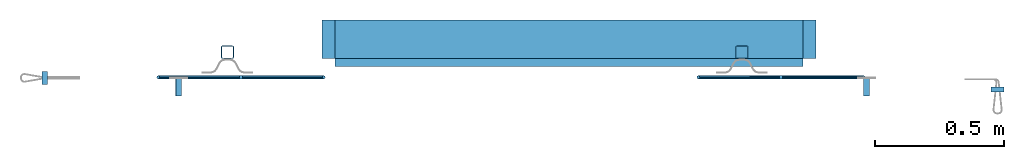
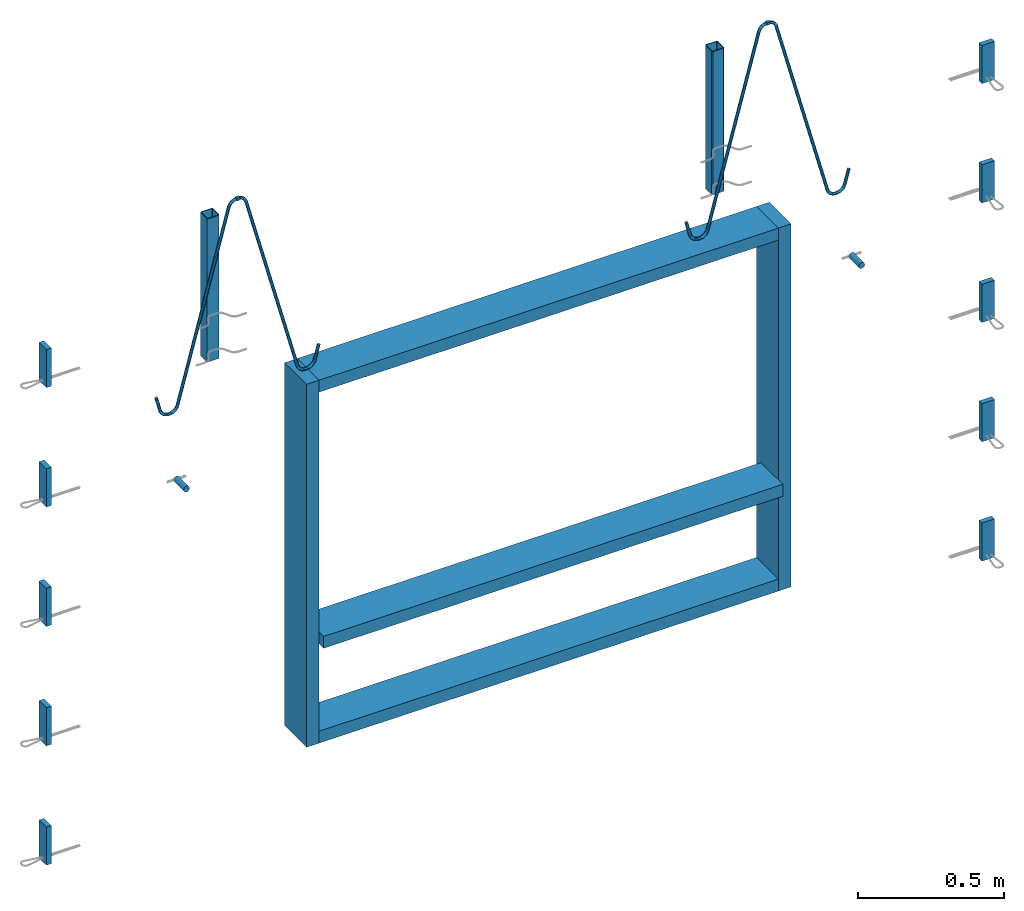
# One storey, part 1 of 5: 11 beams, 10 plates, 2 reinforcing bars, 21 elements without a shape of their own.
"""IFC2X3 building model written with IfcOpenShell, lengths in millimetres."""

from ifc_helpers import new_model, entity, si_unit, frame, origin_with_axes, origin_2d_with_axis, place, context, subcontext, project, spatial, polyline, rectangle, hollow_rectangle, circle, outline, extrude, source, transform, mapped, material, type_object, element, aggregate, save


model = new_model("IFC2X3")

# Units and contexts
model_context = context("Model", 3, precision=1e-05, world=origin_with_axes())
body_context = subcontext(model_context, "Body", "Model", "MODEL_VIEW")
ifc_project = project(units=[si_unit("LENGTHUNIT", "METRE", prefix="MILLI"), si_unit("AREAUNIT", "SQUARE_METRE"), si_unit("VOLUMEUNIT", "CUBIC_METRE"), si_unit("MASSUNIT", "GRAM", prefix="KILO"), si_unit("TIMEUNIT", "SECOND"), si_unit("PLANEANGLEUNIT", "RADIAN"), si_unit("SOLIDANGLEUNIT", "STERADIAN"), si_unit("THERMODYNAMICTEMPERATUREUNIT", "DEGREE_CELSIUS"), si_unit("LUMINOUSINTENSITYUNIT", "LUMEN")], contexts=[model_context])

# Site, building, storey
site_placement = place(None, origin_with_axes())
site = spatial("IfcSite", under=ifc_project, at=site_placement, CompositionType="ELEMENT")
building_placement = place(site_placement, origin_with_axes())
building = spatial("IfcBuilding", under=site, at=building_placement, Name="Undefined", CompositionType="ELEMENT")
storey_placement = place(building_placement, origin_with_axes())
storey = spatial("IfcBuildingStorey", under=building, at=storey_placement, Name="Undefined", CompositionType="ELEMENT", Elevation=0.0)

# Assembly, beam
assembly_1_placement = place(storey_placement, origin_with_axes())
assembly_1 = element("IfcElementAssembly", 1, at=assembly_1_placement, inside=storey, AssemblyPlace="NOTDEFINED", PredefinedType="NOTDEFINED")
ifc_material_1 = material(Name="TIMBER/C24")
beam_type_1 = type_object("IfcBeamType", Name="50X150", PredefinedType="NOTDEFINED")
beam_1_placement = place(assembly_1_placement, frame((37138.5237091595, 6694.96507881058, 1074.99992151564), z_axis=(0.0, 0.0, 1.0), x_axis=(0.999999999544916, -3.0168999986316e-05, 0.0)))
beam_1 = element("IfcBeam", 2, at=beam_1_placement, type_object=beam_type_1, material=ifc_material_1, ObjectType="50X150", context=body_context, shape_type="SweptSolid", body=[
    extrude(rectangle(XDim=150.0, YDim=50.0, at=origin_2d_with_axis()), frame((1819.99999996996, 6.16639985590952e-18, 0.0), z_axis=(-1.0, -1.81898940356404e-12, 1.55293650763585e-12), x_axis=(1.81898940356404e-12, -1.0, -1.87523373262748e-24)), (0.0, 0.0, 1.0), 1820.0),
])
aggregate(assembly_1, [beam_1])

assembly_2_placement = place(storey_placement, origin_with_axes())
assembly_2 = element("IfcElementAssembly", 3, at=assembly_2_placement, inside=storey, AssemblyPlace="NOTDEFINED", PredefinedType="NOTDEFINED")
beam_type_2 = type_object("IfcBeamType", Name="150X50", PredefinedType="NOTDEFINED")
beam_2_placement = place(assembly_2_placement, frame((37138.5246142217, 6724.96507879908, 659.999921515637), z_axis=(-3.01689999832888e-05, -0.999999999544916, 0.0), x_axis=(0.999999999544916, -3.0168999986316e-05, 0.0)))
beam_2 = element("IfcBeam", 4, at=beam_2_placement, type_object=beam_type_2, material=ifc_material_1, ObjectType="150X50", context=body_context, shape_type="SweptSolid", body=[
    extrude(rectangle(XDim=50.0, YDim=150.0, at=origin_2d_with_axis()), frame((1819.99999996996, 6.16639985590952e-18, 0.0), z_axis=(-1.0, -1.81898940356404e-12, 1.55293650763585e-12), x_axis=(1.81898940356404e-12, -1.0, -1.87523373262748e-24)), (0.0, 0.0, 1.0), 1820.0),
])
aggregate(assembly_2, [beam_2])

assembly_3_placement = place(storey_placement, origin_with_axes())
assembly_3 = element("IfcElementAssembly", 5, at=assembly_3_placement, inside=storey, AssemblyPlace="NOTDEFINED", PredefinedType="NOTDEFINED")
beam_3_placement = place(assembly_3_placement, frame((37113.5246142332, 6724.96583302412, 2154.99992151564), z_axis=(-3.01689999832888e-05, -0.999999999544916, 0.0), x_axis=(0.0, 0.0, -1.0)))
beam_3 = element("IfcBeam", 6, at=beam_3_placement, type_object=beam_type_2, material=ifc_material_1, ObjectType="150X50", context=body_context, shape_type="SweptSolid", body=[
    extrude(rectangle(XDim=50.0, YDim=150.0, at=origin_2d_with_axis()), frame((1520.0, -7.27595761418343e-12, -9.09494701772928e-13), z_axis=(-1.0, -1.81898940356404e-12, 1.55293650763585e-12), x_axis=(1.81898940356404e-12, -1.0, -1.87523373262748e-24)), (0.0, 0.0, 1.0), 1520.0),
])
aggregate(assembly_3, [beam_3])

assembly_4_placement = place(storey_placement, origin_with_axes())
assembly_4 = element("IfcElementAssembly", 7, at=assembly_4_placement, inside=storey, AssemblyPlace="NOTDEFINED", PredefinedType="NOTDEFINED")
beam_4_placement = place(assembly_4_placement, frame((38958.5246125429, 6724.91017122622, 2129.99992151563), z_axis=(-3.01689999832888e-05, -0.999999999544916, 0.0), x_axis=(-0.999999999544916, 3.01689999841786e-05, 0.0)))
beam_4 = element("IfcBeam", 8, at=beam_4_placement, type_object=beam_type_2, material=ifc_material_1, ObjectType="150X50", context=body_context, shape_type="SweptSolid", body=[
    extrude(rectangle(XDim=50.0, YDim=150.0, at=origin_2d_with_axis()), frame((1819.99999996996, 6.16639985590952e-18, 0.0), z_axis=(-1.0, -1.81898940356404e-12, 1.55293650763585e-12), x_axis=(1.81898940356404e-12, -1.0, -1.87523373262748e-24)), (0.0, 0.0, 1.0), 1820.0),
])
aggregate(assembly_4, [beam_4])

assembly_5_placement = place(storey_placement, origin_with_axes())
assembly_5 = element("IfcElementAssembly", 9, at=assembly_5_placement, inside=storey, AssemblyPlace="NOTDEFINED", PredefinedType="NOTDEFINED")
beam_5_placement = place(assembly_5_placement, frame((38983.5246125315, 6724.90941700118, 634.999921515635), z_axis=(-3.01689999832888e-05, -0.999999999544916, 0.0), x_axis=(0.0, 0.0, 1.0)))
beam_5 = element("IfcBeam", 10, at=beam_5_placement, type_object=beam_type_2, material=ifc_material_1, ObjectType="150X50", context=body_context, shape_type="SweptSolid", body=[
    extrude(rectangle(XDim=50.0, YDim=150.0, at=origin_2d_with_axis()), frame((1520.0, -7.27595761418343e-12, -9.09494701772928e-13), z_axis=(-1.0, -1.81898940356404e-12, 1.55293650763585e-12), x_axis=(1.81898940356404e-12, -1.0, -1.87523373262748e-24)), (0.0, 0.0, 1.0), 1520.0),
])
aggregate(assembly_5, [beam_5])

assembly_6_placement = place(storey_placement, origin_with_axes())
assembly_6 = element("IfcElementAssembly", 11, at=assembly_6_placement, inside=storey, Name="Steel Assembly", AssemblyPlace="NOTDEFINED", PredefinedType="RIGID_FRAME")
ifc_material_2 = material(Name="STEEL/S235JR")
beam_type_3 = type_object("IfcBeamType", Name="12X12", PredefinedType="NOTDEFINED")
beam_6_placement = place(assembly_6_placement, frame((38878.7217910362, 6577.27924703083, 3088.99992148861), z_axis=(0.0, 0.0, 1.0), x_axis=(-0.999999999544916, 3.01689999841786e-05, 0.0)))
beam_6 = element("IfcBeam", 12, at=beam_6_placement, type_object=beam_type_3, material=ifc_material_2, Name="SA_12", ObjectType="12X12", context=body_context, shape_type="SweptSolid", body=[
    extrude(rectangle(XDim=12.0, YDim=12.0, at=origin_2d_with_axis()), frame((11.9999999996475, 0.0, 4.54747350886464e-13), z_axis=(-1.0, -1.81898940356404e-12, 1.55293650763585e-12), x_axis=(1.81898940356404e-12, -1.0, -1.87523373262748e-24)), (0.0, 0.0, 1.0), 12.0),
])

assembly_7_placement = place(storey_placement, origin_with_axes())
assembly_7 = element("IfcElementAssembly", 13, at=assembly_7_placement, inside=storey, Name="Steel Assembly", AssemblyPlace="NOTDEFINED", PredefinedType="RIGID_FRAME")
beam_7_placement = place(assembly_7_placement, frame((36766.7217920601, 6577.34296393511, 3088.9999214886), z_axis=(0.0, 0.0, 1.0), x_axis=(0.999999999544916, -3.0168999986316e-05, 0.0)))
beam_7 = element("IfcBeam", 14, at=beam_7_placement, type_object=beam_type_3, material=ifc_material_2, Name="SA_12", ObjectType="12X12", context=body_context, shape_type="SweptSolid", body=[
    extrude(rectangle(XDim=12.0, YDim=12.0, at=origin_2d_with_axis()), frame((11.9999999996475, 0.0, 4.54747350886464e-13), z_axis=(-1.0, -1.81898940356404e-12, 1.55293650763585e-12), x_axis=(1.81898940356404e-12, -1.0, -1.87523373262748e-24)), (0.0, 0.0, 1.0), 12.0),
])

assembly_8_placement = place(storey_placement, origin_with_axes())
assembly_8 = element("IfcElementAssembly", 15, at=assembly_8_placement, inside=storey, Name="Steel Assembly", AssemblyPlace="NOTDEFINED", PredefinedType="RIGID_FRAME")
ifc_material_3 = material(Name="STEEL/S235J0")
beam_type_4 = type_object("IfcBeamType", Name="P50X50X3", PredefinedType="NOTDEFINED")
beam_8_placement = place(assembly_8_placement, frame((38720.0052770565, 6674.9173671186, 2984.99992151562), z_axis=(0.999999999544916, -3.0168999986316e-05, 0.0), x_axis=(0.0, 0.0, -1.0)))
beam_8 = element("IfcBeam", 16, at=beam_8_placement, type_object=beam_type_4, material=ifc_material_3, Name="200", ObjectType="P50X50X3", context=body_context, shape_type="SweptSolid", body=[
    extrude(hollow_rectangle(XDim=50.0, YDim=50.0, WallThickness=3.0, InnerFilletRadius=3.0, OuterFilletRadius=6.0, at=origin_2d_with_axis()), frame((600.0, 9.09494701772928e-13, 0.0), z_axis=(-1.0, -1.81898940356404e-12, 1.55293650763585e-12), x_axis=(1.81898940356404e-12, -1.0, -1.87523373262748e-24)), (0.0, 0.0, 1.0), 600.0),
])
aggregate(assembly_8, [beam_8])

assembly_9_placement = place(storey_placement, origin_with_axes())
assembly_9 = element("IfcElementAssembly", 17, at=assembly_9_placement, inside=storey, Name="Steel Assembly", AssemblyPlace="NOTDEFINED", PredefinedType="RIGID_FRAME")
beam_9_placement = place(assembly_9_placement, frame((36720.0052789693, 6674.9777050962, 2984.99992151562), z_axis=(0.999999999544916, -3.0168999986316e-05, 0.0), x_axis=(0.0, 0.0, -1.0)))
beam_9 = element("IfcBeam", 18, at=beam_9_placement, type_object=beam_type_4, material=ifc_material_3, Name="200", ObjectType="P50X50X3", context=body_context, shape_type="SweptSolid", body=[
    extrude(hollow_rectangle(XDim=50.0, YDim=50.0, WallThickness=3.0, InnerFilletRadius=3.0, OuterFilletRadius=6.0, at=origin_2d_with_axis()), frame((600.0, 9.09494701772928e-13, 0.0), z_axis=(-1.0, -1.81898940356404e-12, 1.55293650763585e-12), x_axis=(1.81898940356404e-12, -1.0, -1.87523373262748e-24)), (0.0, 0.0, 1.0), 600.0),
])
aggregate(assembly_9, [beam_9])

assembly_10_placement = place(storey_placement, origin_with_axes())
assembly_10 = element("IfcElementAssembly", 19, at=assembly_10_placement, inside=storey, Name="Steel Assembly", AssemblyPlace="NOTDEFINED", PredefinedType="RIGID_FRAME")
ifc_material_4 = material()
beam_type_5 = type_object("IfcBeamType", Name="D24", PredefinedType="NOTDEFINED")
beam_10_placement = place(assembly_10_placement, frame((39204.4034583971, 6504.90275308546, 1999.99992149192), z_axis=(0.0, 0.0, 1.0), x_axis=(3.01689999468154e-05, 0.999999999544916, 0.0)))
beam_10 = element("IfcBeam", 20, at=beam_10_placement, type_object=beam_type_5, material=ifc_material_4, ObjectType="D24", context=body_context, shape_type="SweptSolid", body=[
    extrude(circle(Radius=12.0, at=origin_2d_with_axis()), frame((70.0000000002146, 0.0, 2.27373675443232e-13), z_axis=(-1.0, -1.81898940356404e-12, 1.55293650763585e-12), x_axis=(1.81898940356404e-12, -1.0, -1.87523373262748e-24)), (0.0, 0.0, 1.0), 70.0),
])
aggregate(assembly_10, [beam_10])

assembly_11_placement = place(storey_placement, origin_with_axes())
assembly_11 = element("IfcElementAssembly", 21, at=assembly_11_placement, inside=storey, Name="Steel Assembly", AssemblyPlace="NOTDEFINED", PredefinedType="RIGID_FRAME")
beam_11_placement = place(assembly_11_placement, frame((36530.0001506199, 6504.98343725059, 1999.99992151153), z_axis=(0.0, 0.0, 1.0), x_axis=(3.01689999468154e-05, 0.999999999544916, 0.0)))
beam_11 = element("IfcBeam", 22, at=beam_11_placement, type_object=beam_type_5, material=ifc_material_4, ObjectType="D24", context=body_context, shape_type="SweptSolid", body=[
    extrude(circle(Radius=12.0, at=origin_2d_with_axis()), frame((70.0000000002146, 0.0, 2.27373675443232e-13), z_axis=(-1.0, -1.81898940356404e-12, 1.55293650763585e-12), x_axis=(1.81898940356404e-12, -1.0, -1.87523373262748e-24)), (0.0, 0.0, 1.0), 70.0),
])
aggregate(assembly_11, [beam_11])

# Assembly, plate
assembly_12_placement = place(storey_placement, origin_with_axes())
assembly_12 = element("IfcElementAssembly", 23, at=assembly_12_placement, inside=storey, Name="Steel Assembly", AssemblyPlace="NOTDEFINED", PredefinedType="RIGID_FRAME")
ifc_material_5 = material(Name="STEEL/Steel_Undefined")
plate_type = type_object("IfcPlateType", Name="PL160X20", PredefinedType="NOTDEFINED")
plate_1_placement = place(assembly_12_placement, frame((36000.0015084882, 6549.99942681672, 2662.49992151557), z_axis=(0.0, 0.0, -1.0), x_axis=(3.01689999468154e-05, 0.999999999544916, 0.0)))
plate_1 = element("IfcPlate", 24, at=plate_1_placement, type_object=plate_type, material=ifc_material_5, Name="PVL80", ObjectType="PL160X20", context=body_context, shape_type="SweptSolid", body=[
    extrude(outline(polyline([(0.0, 0.0), (50.000000000101, 1.96450855582952e-10), (50.0000000001401, 19.9999999997963), (-3.09228198602796e-11, 19.9999999995998), (0.0, 0.0)])), frame((0.0, 0.0, -80.0000000000005), z_axis=(0.0, 0.0, 1.0), x_axis=(1.0, 0.0, 0.0)), (0.0, 0.0, 1.0), 160.0),
])
aggregate(assembly_12, [plate_1])

assembly_13_placement = place(storey_placement, origin_with_axes())
assembly_13 = element("IfcElementAssembly", 25, at=assembly_13_placement, inside=storey, Name="Steel Assembly", AssemblyPlace="NOTDEFINED", PredefinedType="RIGID_FRAME")
plate_2_placement = place(assembly_13_placement, frame((39739.4018553944, 6519.89476329136, 2662.49992151563), z_axis=(0.0, 0.0, -1.0), x_axis=(-0.999999999544916, 3.01689999841786e-05, 0.0)))
plate_2 = element("IfcPlate", 26, at=plate_2_placement, type_object=plate_type, material=ifc_material_5, Name="PVL80", ObjectType="PL160X20", context=body_context, shape_type="SweptSolid", body=[
    extrude(outline(polyline([(0.0, 0.0), (50.000000000101, 1.96450855582952e-10), (50.0000000001401, 19.9999999997963), (-3.09228198602796e-11, 19.9999999995998), (0.0, 0.0)])), frame((0.0, 0.0, -80.0000000000005), z_axis=(0.0, 0.0, 1.0), x_axis=(1.0, 0.0, 0.0)), (0.0, 0.0, 1.0), 160.0),
])
aggregate(assembly_13, [plate_2])

assembly_14_placement = place(storey_placement, origin_with_axes())
assembly_14 = element("IfcElementAssembly", 27, at=assembly_14_placement, inside=storey, Name="Steel Assembly", AssemblyPlace="NOTDEFINED", PredefinedType="RIGID_FRAME")
plate_3_placement = place(assembly_14_placement, frame((39739.4018553907, 6519.89476329159, 2162.49992151543), z_axis=(0.0, 0.0, -1.0), x_axis=(-0.999999999544916, 3.01689999841786e-05, 0.0)))
plate_3 = element("IfcPlate", 28, at=plate_3_placement, type_object=plate_type, material=ifc_material_5, Name="PVL80", ObjectType="PL160X20", context=body_context, shape_type="SweptSolid", body=[
    extrude(outline(polyline([(0.0, 0.0), (50.000000000101, 1.96450855582952e-10), (50.0000000001401, 19.9999999997963), (-3.09228198602796e-11, 19.9999999995998), (0.0, 0.0)])), frame((0.0, 0.0, -80.0000000000005), z_axis=(0.0, 0.0, 1.0), x_axis=(1.0, 0.0, 0.0)), (0.0, 0.0, 1.0), 160.0),
])
aggregate(assembly_14, [plate_3])

assembly_15_placement = place(storey_placement, origin_with_axes())
assembly_15 = element("IfcElementAssembly", 29, at=assembly_15_placement, inside=storey, Name="Steel Assembly", AssemblyPlace="NOTDEFINED", PredefinedType="RIGID_FRAME")
plate_4_placement = place(assembly_15_placement, frame((39739.4018553916, 6519.89476329159, 1662.49992151543), z_axis=(0.0, 0.0, -1.0), x_axis=(-0.999999999544916, 3.01689999841786e-05, 0.0)))
plate_4 = element("IfcPlate", 30, at=plate_4_placement, type_object=plate_type, material=ifc_material_5, Name="PVL80", ObjectType="PL160X20", context=body_context, shape_type="SweptSolid", body=[
    extrude(outline(polyline([(0.0, 0.0), (50.000000000101, 1.96450855582952e-10), (50.0000000001401, 19.9999999997963), (-3.09228198602796e-11, 19.9999999995998), (0.0, 0.0)])), frame((0.0, 0.0, -80.0000000000005), z_axis=(0.0, 0.0, 1.0), x_axis=(1.0, 0.0, 0.0)), (0.0, 0.0, 1.0), 160.0),
])
aggregate(assembly_15, [plate_4])

assembly_16_placement = place(storey_placement, origin_with_axes())
assembly_16 = element("IfcElementAssembly", 31, at=assembly_16_placement, inside=storey, Name="Steel Assembly", AssemblyPlace="NOTDEFINED", PredefinedType="RIGID_FRAME")
plate_5_placement = place(assembly_16_placement, frame((39739.4018553925, 6519.89476329159, 1162.49992151543), z_axis=(0.0, 0.0, -1.0), x_axis=(-0.999999999544916, 3.01689999841786e-05, 0.0)))
plate_5 = element("IfcPlate", 32, at=plate_5_placement, type_object=plate_type, material=ifc_material_5, Name="PVL80", ObjectType="PL160X20", context=body_context, shape_type="SweptSolid", body=[
    extrude(outline(polyline([(0.0, 0.0), (50.000000000101, 1.96450855582952e-10), (50.0000000001401, 19.9999999997963), (-3.09228198602796e-11, 19.9999999995998), (0.0, 0.0)])), frame((0.0, 0.0, -80.0000000000005), z_axis=(0.0, 0.0, 1.0), x_axis=(1.0, 0.0, 0.0)), (0.0, 0.0, 1.0), 160.0),
])
aggregate(assembly_16, [plate_5])

assembly_17_placement = place(storey_placement, origin_with_axes())
assembly_17 = element("IfcElementAssembly", 33, at=assembly_17_placement, inside=storey, Name="Steel Assembly", AssemblyPlace="NOTDEFINED", PredefinedType="RIGID_FRAME")
plate_6_placement = place(assembly_17_placement, frame((39739.4018553934, 6519.89476329159, 662.499921515427), z_axis=(0.0, 0.0, -1.0), x_axis=(-0.999999999544916, 3.01689999841786e-05, 0.0)))
plate_6 = element("IfcPlate", 34, at=plate_6_placement, type_object=plate_type, material=ifc_material_5, Name="PVL80", ObjectType="PL160X20", context=body_context, shape_type="SweptSolid", body=[
    extrude(outline(polyline([(0.0, 0.0), (50.000000000101, 1.96450855582952e-10), (50.0000000001401, 19.9999999997963), (-3.09228198602796e-11, 19.9999999995998), (0.0, 0.0)])), frame((0.0, 0.0, -80.0000000000005), z_axis=(0.0, 0.0, 1.0), x_axis=(1.0, 0.0, 0.0)), (0.0, 0.0, 1.0), 160.0),
])
aggregate(assembly_17, [plate_6])

assembly_18_placement = place(storey_placement, origin_with_axes())
assembly_18 = element("IfcElementAssembly", 35, at=assembly_18_placement, inside=storey, Name="Steel Assembly", AssemblyPlace="NOTDEFINED", PredefinedType="RIGID_FRAME")
plate_7_placement = place(assembly_18_placement, frame((36000.0015084842, 6549.99942681677, 2162.49992151551), z_axis=(0.0, 0.0, -1.0), x_axis=(3.01689999468154e-05, 0.999999999544916, 0.0)))
plate_7 = element("IfcPlate", 36, at=plate_7_placement, type_object=plate_type, material=ifc_material_5, Name="PVL80", ObjectType="PL160X20", context=body_context, shape_type="SweptSolid", body=[
    extrude(outline(polyline([(0.0, 0.0), (50.000000000101, 1.96450855582952e-10), (50.0000000001401, 19.9999999997963), (-3.09228198602796e-11, 19.9999999995998), (0.0, 0.0)])), frame((0.0, 0.0, -80.0000000000005), z_axis=(0.0, 0.0, 1.0), x_axis=(1.0, 0.0, 0.0)), (0.0, 0.0, 1.0), 160.0),
])
aggregate(assembly_18, [plate_7])

assembly_19_placement = place(storey_placement, origin_with_axes())
assembly_19 = element("IfcElementAssembly", 37, at=assembly_19_placement, inside=storey, Name="Steel Assembly", AssemblyPlace="NOTDEFINED", PredefinedType="RIGID_FRAME")
plate_8_placement = place(assembly_19_placement, frame((36000.0015084851, 6549.99942681677, 1662.49992151551), z_axis=(0.0, 0.0, -1.0), x_axis=(3.01689999468154e-05, 0.999999999544916, 0.0)))
plate_8 = element("IfcPlate", 38, at=plate_8_placement, type_object=plate_type, material=ifc_material_5, Name="PVL80", ObjectType="PL160X20", context=body_context, shape_type="SweptSolid", body=[
    extrude(outline(polyline([(0.0, 0.0), (50.000000000101, 1.96450855582952e-10), (50.0000000001401, 19.9999999997963), (-3.09228198602796e-11, 19.9999999995998), (0.0, 0.0)])), frame((0.0, 0.0, -80.0000000000005), z_axis=(0.0, 0.0, 1.0), x_axis=(1.0, 0.0, 0.0)), (0.0, 0.0, 1.0), 160.0),
])
aggregate(assembly_19, [plate_8])

assembly_20_placement = place(storey_placement, origin_with_axes())
assembly_20 = element("IfcElementAssembly", 39, at=assembly_20_placement, inside=storey, Name="Steel Assembly", AssemblyPlace="NOTDEFINED", PredefinedType="RIGID_FRAME")
plate_9_placement = place(assembly_20_placement, frame((36000.001508486, 6549.99942681677, 1162.49992151551), z_axis=(0.0, 0.0, -1.0), x_axis=(3.01689999468154e-05, 0.999999999544916, 0.0)))
plate_9 = element("IfcPlate", 40, at=plate_9_placement, type_object=plate_type, material=ifc_material_5, Name="PVL80", ObjectType="PL160X20", context=body_context, shape_type="SweptSolid", body=[
    extrude(outline(polyline([(0.0, 0.0), (50.000000000101, 1.96450855582952e-10), (50.0000000001401, 19.9999999997963), (-3.09228198602796e-11, 19.9999999995998), (0.0, 0.0)])), frame((0.0, 0.0, -80.0000000000005), z_axis=(0.0, 0.0, 1.0), x_axis=(1.0, 0.0, 0.0)), (0.0, 0.0, 1.0), 160.0),
])
aggregate(assembly_20, [plate_9])

assembly_21_placement = place(storey_placement, origin_with_axes())
assembly_21 = element("IfcElementAssembly", 41, at=assembly_21_placement, inside=storey, Name="Steel Assembly", AssemblyPlace="NOTDEFINED", PredefinedType="RIGID_FRAME")
plate_10_placement = place(assembly_21_placement, frame((36000.001508487, 6549.99942681677, 662.499921515511), z_axis=(0.0, 0.0, -1.0), x_axis=(3.01689999468154e-05, 0.999999999544916, 0.0)))
plate_10 = element("IfcPlate", 42, at=plate_10_placement, type_object=plate_type, material=ifc_material_5, Name="PVL80", ObjectType="PL160X20", context=body_context, shape_type="SweptSolid", body=[
    extrude(outline(polyline([(0.0, 0.0), (50.000000000101, 1.96450855582952e-10), (50.0000000001401, 19.9999999997963), (-3.09228198602796e-11, 19.9999999995998), (0.0, 0.0)])), frame((0.0, 0.0, -80.0000000000005), z_axis=(0.0, 0.0, 1.0), x_axis=(1.0, 0.0, 0.0)), (0.0, 0.0, 1.0), 160.0),
])
aggregate(assembly_21, [plate_10])

# Reinforcing bar
ifc_material_6 = material(Name="S235JR")
ifc_direction_1 = entity("IfcDirection", [-0.866025403785561, 2.83708327271961e-12, -0.499999999998057])
ifc_direction_2 = entity("IfcDirection", [1.81898940356404e-12, -1.0, -1.87523373262748e-24])
ifc_direction_3 = entity("IfcDirection", [-0.499999999998057, -1.93141731620261e-12, 0.866025403785561])
vector = entity("IfcVector", entity("IfcDirection", [1.0, 0.0, 0.0]), 1.0)
ifc_direction_4 = entity("IfcDirection", [0.0, 1.0, 0.0])
shared_shape_1 = source(origin_with_axes(), body_context, "Body", "AdvancedSweptSolid", [
    entity("IfcSweptDiskSolid", entity("IfcCompositeCurve", [entity("IfcCompositeCurveSegment", "CONTINUOUS", True, entity("IfcTrimmedCurve", entity("IfcLine", entity("IfcCartesianPoint", [0.0, 0.0, 0.0]), entity("IfcVector", ifc_direction_1, 1.0)), [entity("IfcParameterValue", 0.0)], [entity("IfcParameterValue", 61.154700538264)], True, "PARAMETER")), entity("IfcCompositeCurveSegment", "CONTINUOUS", True, entity("IfcTrimmedCurve", entity("IfcCircle", entity("IfcAxis2Placement3D", entity("IfcCartesianPoint", [-35.9615242271012, 2.39169166696174e-10, -60.0222139977222]), ifc_direction_2, ifc_direction_3), 34.0), [entity("IfcParameterValue", 0.0)], [entity("IfcParameterValue", 1.04719755119782)], True, "PARAMETER")), entity("IfcCompositeCurveSegment", "CONTINUOUS", True, entity("IfcTrimmedCurve", entity("IfcLine", entity("IfcCartesianPoint", [-69.9615242271012, 2.89872602672979e-10, -60.0222139976874]), entity("IfcVector", entity("IfcDirection", [0.0, 0.0, -1.0]), 1.0)), [entity("IfcParameterValue", 0.0)], [entity("IfcParameterValue", 3.15470053787173)], True, "PARAMETER")), entity("IfcCompositeCurveSegment", "CONTINUOUS", True, entity("IfcTrimmedCurve", entity("IfcCircle", entity("IfcAxis2Placement3D", entity("IfcCartesianPoint", [-35.9615242271045, 3.20453102700974e-10, -63.176914535594]), ifc_direction_2, entity("IfcDirection", [-1.0, -1.81898940356404e-12, 1.55293650763585e-12])), 34.0), [entity("IfcParameterValue", 0.0)], [entity("IfcParameterValue", 1.57079632679656)], True, "PARAMETER")), entity("IfcCompositeCurveSegment", "CONTINUOUS", True, entity("IfcTrimmedCurve", entity("IfcLine", entity("IfcCartesianPoint", [-35.9615242270828, 4.25553838015961e-10, -97.176914535594]), vector), [entity("IfcParameterValue", 0.0)], [entity("IfcParameterValue", 784.66298456314)], True, "PARAMETER")), entity("IfcCompositeCurveSegment", "CONTINUOUS", True, entity("IfcTrimmedCurve", entity("IfcCircle", entity("IfcAxis2Placement3D", entity("IfcCartesianPoint", [748.701460336079, 9.09356052640168e-10, -131.176914535094]), ifc_direction_4, entity("IfcDirection", [0.0, 0.0, 1.0])), 34.0), [entity("IfcParameterValue", 0.0)], [entity("IfcParameterValue", 1.3089969389998)], True, "PARAMETER")), entity("IfcCompositeCurveSegment", "CONTINUOUS", True, entity("IfcTrimmedCurve", entity("IfcLine", entity("IfcCartesianPoint", [781.542938429938, 9.2866988173538e-10, -122.37706700172]), entity("IfcVector", entity("IfcDirection", [0.258819045099217, 2.46932619129979e-13, -0.965925826289953]), 1.0)), [entity("IfcParameterValue", 0.0)], [entity("IfcParameterValue", 3.06930795123042)], True, "PARAMETER")), entity("IfcCompositeCurveSegment", "CONTINUOUS", True, entity("IfcTrimmedCurve", entity("IfcCircle", entity("IfcAxis2Placement3D", entity("IfcCartesianPoint", [749.495855689132, 1.05932537449818e-09, -134.141638354024]), ifc_direction_4, entity("IfcDirection", [0.965925826289953, -3.82051707386731e-12, 0.25881904509922])), 34.0), [entity("IfcParameterValue", 0.0)], [entity("IfcParameterValue", 1.30899693900263)], True, "PARAMETER")), entity("IfcCompositeCurveSegment", "CONTINUOUS", True, entity("IfcTrimmedCurve", entity("IfcLine", entity("IfcCartesianPoint", [766.495855688829, 1.03381503895176e-09, -163.58650208287]), entity("IfcVector", ifc_direction_1, 1.0)), [entity("IfcParameterValue", 0.0)], [entity("IfcParameterValue", 784.662984562302)], True, "PARAMETER")), entity("IfcCompositeCurveSegment", "CONTINUOUS", True, entity("IfcTrimmedCurve", entity("IfcCircle", entity("IfcAxis2Placement3D", entity("IfcCartesianPoint", [103.957777644215, 4.05696167816722e-09, -585.36285808587]), ifc_direction_2, ifc_direction_3), 34.0), [entity("IfcParameterValue", 0.0)], [entity("IfcParameterValue", 1.57079632679922)], True, "PARAMETER")), entity("IfcCompositeCurveSegment", "CONTINUOUS", True, entity("IfcTrimmedCurve", entity("IfcLine", entity("IfcCartesianPoint", [74.5129139154427, 4.18460607535563e-09, -602.362858085694]), entity("IfcVector", entity("IfcDirection", [0.499999999994813, 2.27435300437497e-12, -0.866025403787434]), 1.0)), [entity("IfcParameterValue", 0.0)], [entity("IfcParameterValue", 3.15470053789177)], True, "PARAMETER")), entity("IfcCompositeCurveSegment", "CONTINUOUS", True, entity("IfcTrimmedCurve", entity("IfcCircle", entity("IfcAxis2Placement3D", entity("IfcCartesianPoint", [105.535127913145, 4.13475970472274e-09, -588.094908893026]), ifc_direction_2, ifc_direction_1), 34.0), [entity("IfcParameterValue", 0.0)], [entity("IfcParameterValue", 1.04719755119528)], True, "PARAMETER")), entity("IfcCompositeCurveSegment", "DISCONTINUOUS", True, entity("IfcTrimmedCurve", entity("IfcLine", entity("IfcCartesianPoint", [105.535127912897, 4.23023835564705e-09, -622.094908893026]), vector), [entity("IfcParameterValue", 0.0)], [entity("IfcParameterValue", 61.1547005383823)], True, "PARAMETER"))], False), 6.0, None, 0.0, 1708.86806086307),
])
reinforcing_bar_1_placement = place(assembly_6_placement, frame((38626.4600871645, 6577.28685750728, 2273.03204920444), z_axis=(-0.965925825826314, 2.91409999945244e-05, 0.25881904518902), x_axis=(0.258819045071245, -7.80800000212319e-06, 0.965925826265891)))
reinforcing_bar_1 = element("IfcReinforcingBar", 43, at=reinforcing_bar_1_placement, material=ifc_material_6, Name="SA_12", BarRole="NOTDEFINED", CrossSectionArea=0.0, NominalDiameter=12.0, context=body_context, shape_type="MappedRepresentation", body=[
    mapped(shared_shape_1, transform((69.9615242271411, -4.05634636990726e-10, 97.1769145356157))),
])

aggregate(assembly_6, [beam_6, reinforcing_bar_1])

ifc_direction_5 = entity("IfcDirection", [-0.866025403785561, 2.83708327271961e-12, -0.499999999998057])
ifc_direction_6 = entity("IfcDirection", [1.81898940356404e-12, -1.0, -1.87523373262748e-24])
ifc_direction_7 = entity("IfcDirection", [-0.499999999998057, -1.93141731620261e-12, 0.866025403785561])
ifc_direction_8 = entity("IfcDirection", [1.0, 0.0, 0.0])
ifc_direction_9 = entity("IfcDirection", [0.0, 1.0, 0.0])
shared_shape_2 = source(origin_with_axes(), body_context, "Body", "AdvancedSweptSolid", [
    entity("IfcSweptDiskSolid", entity("IfcCompositeCurve", [entity("IfcCompositeCurveSegment", "CONTINUOUS", True, entity("IfcTrimmedCurve", entity("IfcLine", entity("IfcCartesianPoint", [0.0, 0.0, 0.0]), entity("IfcVector", ifc_direction_5, 1.0)), [entity("IfcParameterValue", 0.0)], [entity("IfcParameterValue", 61.1547005382647)], True, "PARAMETER")), entity("IfcCompositeCurveSegment", "CONTINUOUS", True, entity("IfcTrimmedCurve", entity("IfcCircle", entity("IfcAxis2Placement3D", entity("IfcCartesianPoint", [-35.9615242271012, 2.39169166696174e-10, -60.0222139977222]), ifc_direction_6, ifc_direction_7), 34.0), [entity("IfcParameterValue", 0.0)], [entity("IfcParameterValue", 1.04719755119782)], True, "PARAMETER")), entity("IfcCompositeCurveSegment", "CONTINUOUS", True, entity("IfcTrimmedCurve", entity("IfcLine", entity("IfcCartesianPoint", [-69.9615242271012, 2.89872602672979e-10, -60.0222139976874]), entity("IfcVector", entity("IfcDirection", [0.0, 0.0, -1.0]), 1.0)), [entity("IfcParameterValue", 0.0)], [entity("IfcParameterValue", 3.15470053787887)], True, "PARAMETER")), entity("IfcCompositeCurveSegment", "CONTINUOUS", True, entity("IfcTrimmedCurve", entity("IfcCircle", entity("IfcAxis2Placement3D", entity("IfcCartesianPoint", [-35.9615242271045, 3.20453102700974e-10, -63.176914535594]), ifc_direction_6, entity("IfcDirection", [-1.0, -1.81898940356404e-12, 1.55293650763585e-12])), 34.0), [entity("IfcParameterValue", 0.0)], [entity("IfcParameterValue", 1.57079632679656)], True, "PARAMETER")), entity("IfcCompositeCurveSegment", "CONTINUOUS", True, entity("IfcTrimmedCurve", entity("IfcLine", entity("IfcCartesianPoint", [-35.9615242270828, 4.25553838015961e-10, -97.176914535594]), entity("IfcVector", ifc_direction_8, 1.0)), [entity("IfcParameterValue", 0.0)], [entity("IfcParameterValue", 784.662984563143)], True, "PARAMETER")), entity("IfcCompositeCurveSegment", "CONTINUOUS", True, entity("IfcTrimmedCurve", entity("IfcCircle", entity("IfcAxis2Placement3D", entity("IfcCartesianPoint", [748.701460336079, 9.09356052640168e-10, -131.176914535094]), ifc_direction_9, entity("IfcDirection", [0.0, 0.0, 1.0])), 34.0), [entity("IfcParameterValue", 0.0)], [entity("IfcParameterValue", 1.30899693899975)], True, "PARAMETER")), entity("IfcCompositeCurveSegment", "CONTINUOUS", True, entity("IfcTrimmedCurve", entity("IfcLine", entity("IfcCartesianPoint", [781.542938429938, 9.2866988173538e-10, -122.37706700172]), entity("IfcVector", entity("IfcDirection", [0.258819045099217, 2.46932619129979e-13, -0.965925826289953]), 1.0)), [entity("IfcParameterValue", 0.0)], [entity("IfcParameterValue", 3.06930795121651)], True, "PARAMETER")), entity("IfcCompositeCurveSegment", "CONTINUOUS", True, entity("IfcTrimmedCurve", entity("IfcCircle", entity("IfcAxis2Placement3D", entity("IfcCartesianPoint", [749.495855689132, 1.05932537449818e-09, -134.141638354024]), ifc_direction_9, entity("IfcDirection", [0.965925826289953, -3.82051707386731e-12, 0.25881904509922])), 34.0), [entity("IfcParameterValue", 0.0)], [entity("IfcParameterValue", 1.30899693900267)], True, "PARAMETER")), entity("IfcCompositeCurveSegment", "CONTINUOUS", True, entity("IfcTrimmedCurve", entity("IfcLine", entity("IfcCartesianPoint", [766.495855688829, 1.03381503895176e-09, -163.58650208287]), entity("IfcVector", ifc_direction_5, 1.0)), [entity("IfcParameterValue", 0.0)], [entity("IfcParameterValue", 784.662984562304)], True, "PARAMETER")), entity("IfcCompositeCurveSegment", "CONTINUOUS", True, entity("IfcTrimmedCurve", entity("IfcCircle", entity("IfcAxis2Placement3D", entity("IfcCartesianPoint", [103.957777644215, 4.05696167816722e-09, -585.36285808587]), ifc_direction_6, ifc_direction_7), 34.0), [entity("IfcParameterValue", 0.0)], [entity("IfcParameterValue", 1.57079632679929)], True, "PARAMETER")), entity("IfcCompositeCurveSegment", "CONTINUOUS", True, entity("IfcTrimmedCurve", entity("IfcLine", entity("IfcCartesianPoint", [74.5129139154427, 4.18460607535563e-09, -602.362858085694]), entity("IfcVector", entity("IfcDirection", [0.499999999994813, 2.27435300437497e-12, -0.866025403787434]), 1.0)), [entity("IfcParameterValue", 0.0)], [entity("IfcParameterValue", 3.15470053789207)], True, "PARAMETER")), entity("IfcCompositeCurveSegment", "CONTINUOUS", True, entity("IfcTrimmedCurve", entity("IfcCircle", entity("IfcAxis2Placement3D", entity("IfcCartesianPoint", [105.535127913145, 4.13475970472274e-09, -588.094908893026]), ifc_direction_6, ifc_direction_5), 34.0), [entity("IfcParameterValue", 0.0)], [entity("IfcParameterValue", 1.04719755119528)], True, "PARAMETER")), entity("IfcCompositeCurveSegment", "DISCONTINUOUS", True, entity("IfcTrimmedCurve", entity("IfcLine", entity("IfcCartesianPoint", [105.535127912897, 4.23023835564705e-09, -622.094908893026]), entity("IfcVector", ifc_direction_8, 1.0)), [entity("IfcParameterValue", 0.0)], [entity("IfcParameterValue", 61.1547005383795)], True, "PARAMETER"))], False), 6.0, None, 0.0, 1708.86806086307),
])
reinforcing_bar_2_placement = place(assembly_7_placement, frame((37018.9834959317, 6577.33535345866, 2273.03204920443), z_axis=(0.965925825826314, -2.91409999945245e-05, 0.258819045189019), x_axis=(-0.258819045071244, 7.80800000212317e-06, 0.965925826265891)))
reinforcing_bar_2 = element("IfcReinforcingBar", 44, at=reinforcing_bar_2_placement, material=ifc_material_6, Name="SA_12", BarRole="NOTDEFINED", CrossSectionArea=0.0, NominalDiameter=12.0, context=body_context, shape_type="MappedRepresentation", body=[
    mapped(shared_shape_2, transform((69.9615242271411, -4.05634636990726e-10, 97.1769145356157))),
])

aggregate(assembly_7, [beam_7, reinforcing_bar_2])

save(model, "model.ifc")
